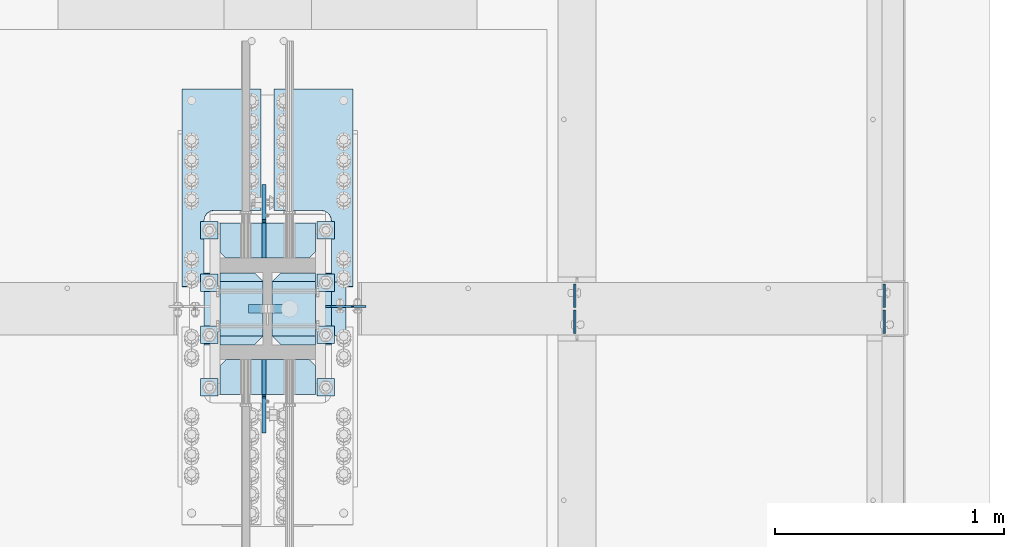
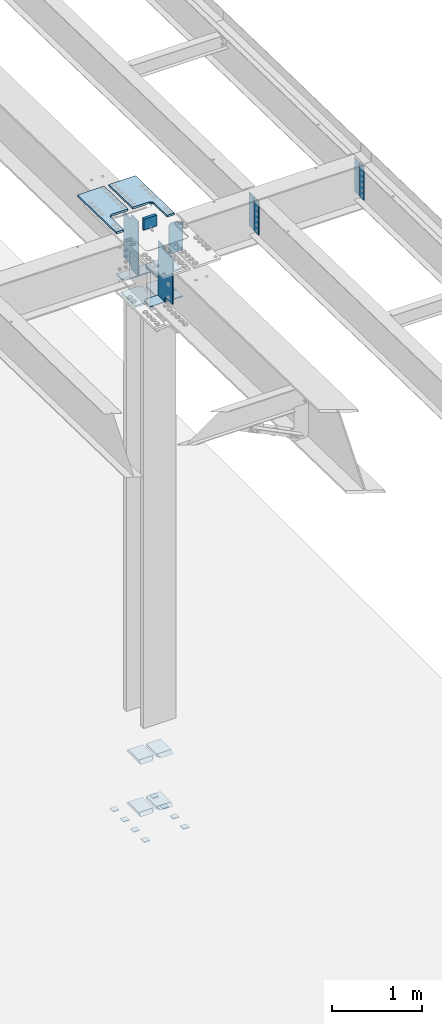
# One storey, part 1572 of 1763: 27 plates, 5 elements without a shape of their own.
"""IFC2X3 building model written with IfcOpenShell, lengths in millimetres."""

from ifc_helpers import new_model, si_unit, frame, origin_with_axes, place, context, subcontext, project, spatial, faceted_brep, material, type_object, element, aggregate, save


model = new_model("IFC2X3")

# Units and contexts
model_context = context("Model", 3, precision=1e-05, world=origin_with_axes())
body_context = subcontext(model_context, "Body", "Model", "MODEL_VIEW")
ifc_project = project(units=[si_unit("LENGTHUNIT", "METRE", prefix="MILLI"), si_unit("AREAUNIT", "SQUARE_METRE"), si_unit("VOLUMEUNIT", "CUBIC_METRE"), si_unit("MASSUNIT", "GRAM", prefix="KILO"), si_unit("TIMEUNIT", "SECOND"), si_unit("PLANEANGLEUNIT", "RADIAN"), si_unit("SOLIDANGLEUNIT", "STERADIAN"), si_unit("THERMODYNAMICTEMPERATUREUNIT", "DEGREE_CELSIUS"), si_unit("LUMINOUSINTENSITYUNIT", "LUMEN")], contexts=[model_context])

# Site, building, storey
site_placement = place(None, origin_with_axes())
site = spatial("IfcSite", under=ifc_project, at=site_placement, CompositionType="ELEMENT")
building_placement = place(site_placement, origin_with_axes())
building = spatial("IfcBuilding", under=site, at=building_placement, Name="Undefined", CompositionType="ELEMENT")
storey_placement = place(building_placement, origin_with_axes())
storey = spatial("IfcBuildingStorey", under=building, at=storey_placement, Name="Undefined", CompositionType="ELEMENT", Elevation=0.0)

# Assembly, plates
assembly_1_placement = place(storey_placement, origin_with_axes())
assembly_1 = element("IfcElementAssembly", 1, at=assembly_1_placement, inside=storey, Name="TEMPLATE", AssemblyPlace="NOTDEFINED", PredefinedType="RIGID_FRAME")
ifc_material_1 = material(Name="STEEL/A36")
plate_type_1 = type_object("IfcPlateType", PredefinedType="NOTDEFINED")
plate_1_placement = place(assembly_1_placement, frame((-24243.7372736984, 152.399999999998, 3916.3625), z_axis=(-1.0, 0.0, 0.0), x_axis=(0.0, -1.0, 0.0)))
plate_1 = element("IfcPlate", 2, at=plate_1_placement, type_object=plate_type_1, material=ifc_material_1, Name="WASHER PLATE", context=body_context, shape_type="Brep", body=[
    faceted_brep([(0.0, -4.76249999999982, 0.0), (0.0, -4.76250000000073, 76.1999969482422), (0.0, 4.76250000000073, 76.1999969482422), (0.0, 4.76249999999982, 0.0), (76.1999969482422, -4.76249999999982, 76.1999969482422), (76.1999969482422, 4.76249999999982, 76.1999969482422), (76.1999969482931, -4.76249999991705, 0.0), (76.1999969482931, 4.76250000006257, 1.81898940354586e-12)], [[[0, 1, 2, 3]], [[1, 4, 5, 2]], [[4, 6, 7, 5]], [[6, 0, 3, 7]], [[5, 7, 3, 2]], [[6, 4, 1, 0]]]),
])
plate_2_placement = place(assembly_1_placement, frame((-23735.7372736984, 152.399999999998, 3916.3625), z_axis=(-1.0, 0.0, 0.0), x_axis=(0.0, -1.0, 0.0)))
plate_2 = element("IfcPlate", 3, at=plate_2_placement, type_object=plate_type_1, material=ifc_material_1, Name="WASHER PLATE", context=body_context, shape_type="Brep", body=[
    faceted_brep([(0.0, -4.76249999999982, 0.0), (0.0, -4.76250000000073, 76.1999969482422), (0.0, 4.76250000000073, 76.1999969482422), (0.0, 4.76249999999982, 0.0), (76.1999969482422, -4.76249999999982, 76.1999969482422), (76.1999969482422, 4.76249999999982, 76.1999969482422), (76.1999969482931, -4.76249999991705, 0.0), (76.1999969482931, 4.76250000006257, 1.81898940354586e-12)], [[[0, 1, 2, 3]], [[1, 4, 5, 2]], [[4, 6, 7, 5]], [[6, 0, 3, 7]], [[5, 7, 3, 2]], [[6, 4, 1, 0]]]),
])
plate_3_placement = place(assembly_1_placement, frame((-24243.7372736984, 380.999999999998, 3916.3625), z_axis=(-1.0, 0.0, 0.0), x_axis=(0.0, -1.0, 0.0)))
plate_3 = element("IfcPlate", 4, at=plate_3_placement, type_object=plate_type_1, material=ifc_material_1, Name="WASHER PLATE", context=body_context, shape_type="Brep", body=[
    faceted_brep([(0.0, -4.76249999999982, 0.0), (0.0, -4.76250000000073, 76.1999969482422), (0.0, 4.76250000000073, 76.1999969482422), (0.0, 4.76249999999982, 0.0), (76.1999969482422, -4.76249999999982, 76.1999969482422), (76.1999969482422, 4.76249999999982, 76.1999969482422), (76.1999969482931, -4.76249999991705, 0.0), (76.1999969482931, 4.76250000006257, 1.81898940354586e-12)], [[[0, 1, 2, 3]], [[1, 4, 5, 2]], [[4, 6, 7, 5]], [[6, 0, 3, 7]], [[5, 7, 3, 2]], [[6, 4, 1, 0]]]),
])
plate_4_placement = place(assembly_1_placement, frame((-23735.7372736984, 380.999999999998, 3916.3625), z_axis=(-1.0, 0.0, 0.0), x_axis=(0.0, -1.0, 0.0)))
plate_4 = element("IfcPlate", 5, at=plate_4_placement, type_object=plate_type_1, material=ifc_material_1, Name="WASHER PLATE", context=body_context, shape_type="Brep", body=[
    faceted_brep([(0.0, -4.76249999999982, 0.0), (0.0, -4.76250000000073, 76.1999969482422), (0.0, 4.76250000000073, 76.1999969482422), (0.0, 4.76249999999982, 0.0), (76.1999969482422, -4.76249999999982, 76.1999969482422), (76.1999969482422, 4.76249999999982, 76.1999969482422), (76.1999969482931, -4.76249999991705, 0.0), (76.1999969482931, 4.76250000006257, 1.81898940354586e-12)], [[[0, 1, 2, 3]], [[1, 4, 5, 2]], [[4, 6, 7, 5]], [[6, 0, 3, 7]], [[5, 7, 3, 2]], [[6, 4, 1, 0]]]),
])
plate_5_placement = place(assembly_1_placement, frame((-24243.7372736984, 609.599999999998, 3916.3625), z_axis=(-1.0, 0.0, 0.0), x_axis=(0.0, -1.0, 0.0)))
plate_5 = element("IfcPlate", 6, at=plate_5_placement, type_object=plate_type_1, material=ifc_material_1, Name="WASHER PLATE", context=body_context, shape_type="Brep", body=[
    faceted_brep([(0.0, -4.76249999999982, 0.0), (0.0, -4.76250000000073, 76.1999969482422), (0.0, 4.76250000000073, 76.1999969482422), (0.0, 4.76249999999982, 0.0), (76.1999969482422, -4.76249999999982, 76.1999969482422), (76.1999969482422, 4.76249999999982, 76.1999969482422), (76.1999969482931, -4.76249999991705, 0.0), (76.1999969482931, 4.76250000006257, 1.81898940354586e-12)], [[[0, 1, 2, 3]], [[1, 4, 5, 2]], [[4, 6, 7, 5]], [[6, 0, 3, 7]], [[5, 7, 3, 2]], [[6, 4, 1, 0]]]),
])
plate_6_placement = place(assembly_1_placement, frame((-23735.7372736984, 609.599999999998, 3916.3625), z_axis=(-1.0, 0.0, 0.0), x_axis=(0.0, -1.0, 0.0)))
plate_6 = element("IfcPlate", 7, at=plate_6_placement, type_object=plate_type_1, material=ifc_material_1, Name="WASHER PLATE", context=body_context, shape_type="Brep", body=[
    faceted_brep([(0.0, -4.76249999999982, 0.0), (0.0, -4.76250000000073, 76.1999969482422), (0.0, 4.76250000000073, 76.1999969482422), (0.0, 4.76249999999982, 0.0), (76.1999969482422, -4.76249999999982, 76.1999969482422), (76.1999969482422, 4.76249999999982, 76.1999969482422), (76.1999969482931, -4.76249999991705, 0.0), (76.1999969482931, 4.76250000006257, 1.81898940354586e-12)], [[[0, 1, 2, 3]], [[1, 4, 5, 2]], [[4, 6, 7, 5]], [[6, 0, 3, 7]], [[5, 7, 3, 2]], [[6, 4, 1, 0]]]),
])
plate_7_placement = place(assembly_1_placement, frame((-24243.7372736984, 838.199999999998, 3916.3625), z_axis=(-1.0, 0.0, 0.0), x_axis=(0.0, -1.0, 0.0)))
plate_7 = element("IfcPlate", 8, at=plate_7_placement, type_object=plate_type_1, material=ifc_material_1, Name="WASHER PLATE", context=body_context, shape_type="Brep", body=[
    faceted_brep([(0.0, -4.76249999999982, 0.0), (0.0, -4.76250000000073, 76.1999969482422), (0.0, 4.76250000000073, 76.1999969482422), (0.0, 4.76249999999982, 0.0), (76.1999969482422, -4.76249999999982, 76.1999969482422), (76.1999969482422, 4.76249999999982, 76.1999969482422), (76.1999969482931, -4.76249999991705, 0.0), (76.1999969482931, 4.76250000006257, 1.81898940354586e-12)], [[[0, 1, 2, 3]], [[1, 4, 5, 2]], [[4, 6, 7, 5]], [[6, 0, 3, 7]], [[5, 7, 3, 2]], [[6, 4, 1, 0]]]),
])
plate_8_placement = place(assembly_1_placement, frame((-23735.7372736984, 838.199999999998, 3916.3625), z_axis=(-1.0, 0.0, 0.0), x_axis=(0.0, -1.0, 0.0)))
plate_8 = element("IfcPlate", 9, at=plate_8_placement, type_object=plate_type_1, material=ifc_material_1, Name="WASHER PLATE", context=body_context, shape_type="Brep", body=[
    faceted_brep([(0.0, -4.76249999999982, 0.0), (0.0, -4.76250000000073, 76.1999969482422), (0.0, 4.76250000000073, 76.1999969482422), (0.0, 4.76249999999982, 0.0), (76.1999969482422, -4.76249999999982, 76.1999969482422), (76.1999969482422, 4.76249999999982, 76.1999969482422), (76.1999969482931, -4.76249999991705, 0.0), (76.1999969482931, 4.76250000006257, 1.81898940354586e-12)], [[[0, 1, 2, 3]], [[1, 4, 5, 2]], [[4, 6, 7, 5]], [[6, 0, 3, 7]], [[5, 7, 3, 2]], [[6, 4, 1, 0]]]),
])
aggregate(assembly_1, [plate_1, plate_2, plate_3, plate_4, plate_5, plate_6, plate_7, plate_8])

assembly_2_placement = place(storey_placement, origin_with_axes())
assembly_2 = element("IfcElementAssembly", 10, at=assembly_2_placement, inside=storey, Name="COLUMN", AssemblyPlace="NOTDEFINED", PredefinedType="RIGID_FRAME")
plate_type_2 = type_object("IfcPlateType", PredefinedType="NOTDEFINED")
plate_9_placement = place(assembly_2_placement, frame((-24235.7997736984, 300.037499999998, 4114.80000000001), z_axis=(0.0, 1.0, 0.0), x_axis=(1.0, 0.0, 0.0)))
plate_9 = element("IfcPlate", 11, at=plate_9_placement, type_object=plate_type_2, material=ifc_material_1, Name="PLATE", context=body_context, shape_type="Brep", body=[
    faceted_brep([(188.118743896484, -19.0500000000002, 276.22501373291), (150.018745422363, 19.0500000000002, 314.325012207031), (0.0, 19.0500000000002, 314.325012207031), (0.0, -19.0500000000002, 276.225012209207), (188.118743896484, -19.0500000000002, 38.0999984741211), (0.0, -19.0500000000002, 38.099999997823), (0.0, 19.0500000000029, 0.0), (150.018745422363, 19.0500000000002, 0.0), (188.118743896484, 19.0500000000002, 38.0999984741211), (188.118743896484, 19.0500000000002, 276.22501373291)], [[[0, 1, 2, 3]], [[4, 5, 6, 7]], [[8, 4, 7]], [[0, 4, 8, 9]], [[5, 4, 0, 3]], [[6, 5, 3, 2]], [[9, 8, 7, 6, 2, 1]], [[9, 1, 0]]]),
])
plate_10_placement = place(assembly_2_placement, frame((-24007.9935236984, 300.037499999998, 4114.80000000001), z_axis=(0.0, 1.0, 0.0), x_axis=(1.0, 0.0, 0.0)))
plate_10 = element("IfcPlate", 12, at=plate_10_placement, type_object=plate_type_2, material=ifc_material_1, Name="PLATE", context=body_context, shape_type="Brep", body=[
    faceted_brep([(188.118743896484, -19.0500000000002, 38.0999984741211), (0.0, -19.0500000000002, 38.099999997823), (38.0999984741211, 19.0500000000002, 0.0), (188.118743896484, 19.0500000000002, 0.0), (0.0, 19.0500000000002, 38.0999984741211), (0.0, 19.0500000000002, 276.22501373291), (0.0, -19.0500000000002, 276.225012209207), (38.0999984741211, 19.0500000000002, 314.325012207031), (188.118743896484, 19.0500000000002, 314.325012207031), (188.118743896484, -19.0500000000002, 276.22501373291)], [[[0, 1, 2, 3]], [[4, 2, 1]], [[5, 6, 7]], [[8, 7, 6, 9]], [[8, 9, 0, 3]], [[4, 5, 7, 8, 3, 2]], [[1, 6, 5, 4]], [[1, 0, 9, 6]]]),
])
plate_11_placement = place(assembly_2_placement, frame((-24235.7997736984, 300.037499999998, 4826.00000000001), z_axis=(0.0, 1.0, 0.0), x_axis=(1.0, 0.0, 0.0)))
plate_11 = element("IfcPlate", 13, at=plate_11_placement, type_object=plate_type_2, material=ifc_material_1, Name="PLATE", context=body_context, shape_type="Brep", body=[
    faceted_brep([(188.118743896484, -19.0500000000002, 276.22501373291), (150.018745422363, 19.0500000000002, 314.325012207031), (0.0, 19.0500000000002, 314.325012207031), (0.0, -19.0500000000002, 276.225012209207), (188.118743896484, -19.0500000000002, 38.0999984741211), (0.0, -19.0500000000002, 38.099999997823), (0.0, 19.0500000000029, 0.0), (150.018745422363, 19.0500000000002, 0.0), (188.118743896484, 19.0500000000002, 38.0999984741211), (188.118743896484, 19.0500000000002, 276.22501373291)], [[[0, 1, 2, 3]], [[4, 5, 6, 7]], [[8, 4, 7]], [[0, 4, 8, 9]], [[5, 4, 0, 3]], [[6, 5, 3, 2]], [[9, 8, 7, 6, 2, 1]], [[9, 1, 0]]]),
])
plate_12_placement = place(assembly_2_placement, frame((-24007.9935236984, 300.037499999998, 4826.00000000001), z_axis=(0.0, 1.0, 0.0), x_axis=(1.0, 0.0, 0.0)))
plate_12 = element("IfcPlate", 14, at=plate_12_placement, type_object=plate_type_2, material=ifc_material_1, Name="PLATE", context=body_context, shape_type="Brep", body=[
    faceted_brep([(188.118743896484, -19.0500000000002, 38.0999984741211), (0.0, -19.0500000000002, 38.099999997823), (38.0999984741211, 19.0500000000002, 0.0), (188.118743896484, 19.0500000000002, 0.0), (0.0, 19.0500000000002, 38.0999984741211), (0.0, 19.0500000000002, 276.22501373291), (0.0, -19.0500000000002, 276.225012209207), (38.0999984741211, 19.0500000000002, 314.325012207031), (188.118743896484, 19.0500000000002, 314.325012207031), (188.118743896484, -19.0500000000002, 276.22501373291)], [[[0, 1, 2, 3]], [[4, 2, 1]], [[5, 6, 7]], [[8, 7, 6, 9]], [[8, 9, 0, 3]], [[4, 5, 7, 8, 3, 2]], [[1, 6, 5, 4]], [[1, 0, 9, 6]]]),
])

assembly_3_placement = place(storey_placement, origin_with_axes())
assembly_3 = element("IfcElementAssembly", 15, at=assembly_3_placement, inside=storey, Name="BEAM", AssemblyPlace="NOTDEFINED", PredefinedType="RIGID_FRAME")
plate_type_3 = type_object("IfcPlateType", PredefinedType="NOTDEFINED")
plate_13_placement = place(assembly_3_placement, frame((-22687.1937736983, 462.756250000002, 11868.8358367707), z_axis=(0.0, 1.0, 0.0), x_axis=(0.0, 0.0, -1.0)))
plate_13 = element("IfcPlate", 16, at=plate_13_placement, type_object=plate_type_3, material=ifc_material_1, Name="PLATE", context=body_context, shape_type="Brep", body=[
    faceted_brep([(0.0, -3.96900000000096, 0.0), (-1.18234311230481e-11, -3.96900000000096, 101.599998474121), (-1.18234311230481e-11, 3.96900000000096, 101.599998474121), (0.0, 3.96900000000096, 0.0), (457.200012207031, -3.96900000000096, 101.599998474121), (457.200012207031, 3.96900000000096, 101.599998474121), (457.200012207031, -3.96900000000096, 0.0), (457.200012207031, 3.96900000000096, 0.0)], [[[0, 1, 2, 3]], [[1, 4, 5, 2]], [[4, 6, 7, 5]], [[6, 0, 3, 7]], [[5, 7, 3, 2]], [[6, 4, 1, 0]]]),
])
plate_14_placement = place(assembly_3_placement, frame((-21337.8187736983, 462.756250000002, 11868.8358367707), z_axis=(0.0, 1.0, 0.0), x_axis=(0.0, 0.0, -1.0)))
plate_14 = element("IfcPlate", 17, at=plate_14_placement, type_object=plate_type_3, material=ifc_material_1, Name="PLATE", context=body_context, shape_type="Brep", body=[
    faceted_brep([(0.0, -3.96900000000096, 0.0), (-1.18234311230481e-11, -3.96900000000096, 101.599998474121), (-1.18234311230481e-11, 3.96900000000096, 101.599998474121), (0.0, 3.96900000000096, 0.0), (457.200012207031, -3.96900000000096, 101.599998474121), (457.200012207031, 3.96900000000096, 101.599998474121), (457.200012207031, -3.96900000000096, 0.0), (457.200012207031, 3.96900000000096, 0.0)], [[[0, 1, 2, 3]], [[1, 4, 5, 2]], [[4, 6, 7, 5]], [[6, 0, 3, 7]], [[5, 7, 3, 2]], [[6, 4, 1, 0]]]),
])
plate_15_placement = place(assembly_3_placement, frame((-21337.8187736984, 451.643750000003, 11871.723207307), z_axis=(0.0, -1.0, 0.0), x_axis=(0.0, 0.0, -1.0)))
plate_15 = element("IfcPlate", 18, at=plate_15_placement, type_object=plate_type_3, material=ifc_material_1, Name="PLATE", context=body_context, shape_type="Brep", body=[
    faceted_brep([(0.0, -3.96900000000096, 0.0), (-1.18234311230481e-11, -3.96900000000096, 101.599998474121), (-1.18234311230481e-11, 3.96900000000096, 101.599998474121), (0.0, 3.96900000000096, 0.0), (457.200012207031, -3.96900000000096, 101.599998474121), (457.200012207031, 3.96900000000096, 101.599998474121), (457.200012207031, -3.96900000000096, 0.0), (457.200012207031, 3.96900000000096, 0.0)], [[[0, 1, 2, 3]], [[1, 4, 5, 2]], [[4, 6, 7, 5]], [[6, 0, 3, 7]], [[5, 7, 3, 2]], [[6, 4, 1, 0]]]),
])
plate_16_placement = place(assembly_3_placement, frame((-22687.1937736984, 451.643750000003, 11871.723207307), z_axis=(0.0, -1.0, 0.0), x_axis=(0.0, 0.0, -1.0)))
plate_16 = element("IfcPlate", 19, at=plate_16_placement, type_object=plate_type_3, material=ifc_material_1, Name="PLATE", context=body_context, shape_type="Brep", body=[
    faceted_brep([(0.0, -3.96900000000096, 0.0), (-1.18234311230481e-11, -3.96900000000096, 101.599998474121), (-1.18234311230481e-11, 3.96900000000096, 101.599998474121), (0.0, 3.96900000000096, 0.0), (457.200012207031, -3.96900000000096, 101.599998474121), (457.200012207031, 3.96900000000096, 101.599998474121), (457.200012207031, -3.96900000000096, 0.0), (457.200012207031, 3.96900000000096, 0.0)], [[[0, 1, 2, 3]], [[1, 4, 5, 2]], [[4, 6, 7, 5]], [[6, 0, 3, 7]], [[5, 7, 3, 2]], [[6, 4, 1, 0]]]),
])
aggregate(assembly_3, [plate_13, plate_14, plate_15, plate_16])

# Plate
ifc_material_2 = material(Name="STEEL/A572-50")
plate_type_4 = type_object("IfcPlateType", PredefinedType="NOTDEFINED")
plate_17_placement = place(assembly_2_placement, frame((-23819.8747736984, 82.5499450683583, 11144.523238352), z_axis=(-1.0, 0.0, 0.0), x_axis=(0.0, 1.0, 0.0)))
plate_17 = element("IfcPlate", 20, at=plate_17_placement, type_object=plate_type_4, material=ifc_material_2, Name="PLATE", context=body_context, shape_type="Brep", body=[
    faceted_brep([(0.0, -6.34999999999491, 1.45519152283669e-11), (0.0, -6.35000000000036, 415.924987792969), (0.0, 6.35000000000036, 415.924987792969), (0.0, 6.34999999999491, -2.91038304567337e-11), (127.00005531311, -6.35000000000036, 415.924987792969), (127.00005531311, 6.35000000000036, 415.924987792969), (152.400054931641, -6.35000000000036, 390.524988174438), (152.400054931641, 6.35000000000036, 390.524988174438), (152.400054931641, -6.35000000000036, 25.3999996185375), (152.400054931641, 6.35000000000036, 25.3999996185375), (127.00005531311, -6.35000000000036, 7.27595761418343e-12), (127.00005531311, 6.35000000000036, 7.27595761418343e-12)], [[[0, 1, 2, 3]], [[1, 4, 5, 2]], [[4, 6, 7, 5]], [[6, 8, 9, 7]], [[8, 10, 11, 9]], [[10, 0, 3, 11]], [[5, 7, 9, 11, 3, 2]], [[10, 8, 6, 4, 1, 0]]]),
])

plate_18_placement = place(assembly_2_placement, frame((-23819.8747736984, 679.449999999999, 11135.2305555584), z_axis=(-1.0, 0.0, 0.0), x_axis=(0.0, 1.0, 0.0)))
plate_18 = element("IfcPlate", 21, at=plate_18_placement, type_object=plate_type_4, material=ifc_material_2, Name="PLATE", context=body_context, shape_type="Brep", body=[
    faceted_brep([(0.0, -6.35000000000036, 25.3999996185303), (0.0, -6.35000000000036, 390.524988174438), (0.0, 6.35000000000036, 390.524988174438), (-2.63229335373174e-12, 6.34999999999999, 25.3999996185303), (25.3999996185303, -6.35000000000036, 415.924987792969), (25.3999996185303, 6.35000000000036, 415.924987792969), (152.400054931641, -6.35000000000036, 415.924987792969), (152.400054931641, 6.35000000000036, 415.924987792969), (152.400054931641, -6.35000000000036, 7.27595761418343e-12), (152.400054931641, 6.35000000000036, 7.27595761418343e-12), (25.3999996185339, -6.35000000000582, 0.0), (25.3999996185339, 6.35000000000582, 0.0)], [[[0, 1, 2, 3]], [[1, 4, 5, 2]], [[4, 6, 7, 5]], [[6, 8, 9, 7]], [[8, 10, 11, 9]], [[10, 0, 3, 11]], [[5, 7, 9, 11, 3, 2]], [[10, 8, 6, 4, 1, 0]]]),
])

plate_type_5 = type_object("IfcPlateType", PredefinedType="NOTDEFINED")
plate_19_placement = place(assembly_2_placement, frame((-24305.6497736984, 300.037499999998, 11039.9805555584), z_axis=(0.0, 1.0, 0.0), x_axis=(1.0, 0.0, 0.0)))
plate_19 = element("IfcPlate", 22, at=plate_19_placement, type_object=plate_type_5, material=ifc_material_2, Name="PLATE", context=body_context, shape_type="Brep", body=[
    faceted_brep([(0.0, -12.6999999999971, -1.81898940354586e-12), (0.0, -12.7000000000007, 314.325012207031), (0.0, 12.7000000000007, 314.325012207031), (0.0, 12.6999999999971, -1.81898940354586e-12), (219.868751525879, -12.7000000000007, 314.325012207031), (219.868751525879, 12.7000000000007, 314.325012207031), (257.96875, -12.7000000000007, 276.22501373291), (257.96875, 12.7000000000007, 276.22501373291), (257.96875, -12.7000000000007, 38.0999984741211), (257.96875, 12.7000000000007, 38.0999984741211), (219.868751525879, -12.7000000000007, 0.0), (219.868751525879, 12.7000000000007, 0.0)], [[[0, 1, 2, 3]], [[1, 4, 5, 2]], [[4, 6, 7, 5]], [[6, 8, 9, 7]], [[8, 10, 11, 9]], [[10, 0, 3, 11]], [[5, 7, 9, 11, 3, 2]], [[10, 8, 6, 4, 1, 0]]]),
])

plate_20_placement = place(assembly_2_placement, frame((-24007.9935236984, 300.037499999998, 11039.9805555584), z_axis=(0.0, 1.0, 0.0), x_axis=(1.0, 0.0, 0.0)))
plate_20 = element("IfcPlate", 23, at=plate_20_placement, type_object=plate_type_5, material=ifc_material_2, Name="PLATE", context=body_context, shape_type="Brep", body=[
    faceted_brep([(0.0, -12.7000000000007, 38.0999984741211), (0.0, -12.7000000000007, 276.22501373291), (0.0, 12.7000000000007, 276.22501373291), (0.0, 12.7000000000007, 38.0999984741211), (38.0999984741211, -12.7000000000007, 314.325012207031), (38.0999984741211, 12.7000000000007, 314.325012207031), (257.96875, -12.7000000000007, 314.325012207031), (257.96875, 12.7000000000007, 314.325012207031), (257.96875, -12.7000000000007, 0.0), (257.96875, 12.7000000000007, 0.0), (38.0999984741211, -12.7000000000007, 0.0), (38.0999984741211, 12.7000000000007, 0.0)], [[[0, 1, 2, 3]], [[1, 4, 5, 2]], [[4, 6, 7, 5]], [[6, 8, 9, 7]], [[8, 10, 11, 9]], [[10, 0, 3, 11]], [[5, 7, 9, 11, 3, 2]], [[10, 8, 6, 4, 1, 0]]]),
])

plate_type_6 = type_object("IfcPlateType", PredefinedType="NOTDEFINED")
plate_21_placement = place(assembly_2_placement, frame((-24007.9935236984, 300.037499999998, 11313.0836714953), z_axis=(0.0, 1.0, 0.0), x_axis=(1.0, 0.0, 0.0)))
plate_21 = element("IfcPlate", 24, at=plate_21_placement, type_object=plate_type_6, material=ifc_material_2, Name="PLATE", context=body_context, shape_type="Brep", body=[
    faceted_brep([(11.1125007607625, -11.1124999999993, 287.337514493672), (0.0, 7.60761395213194e-07, 276.22501373291), (0.0, 0.0, 38.0999984741211), (11.1125007607625, -11.1124999999993, 26.9874977133604), (321.468750000004, -11.1124999999993, 273.050000269884), (321.46875, 11.1124999999993, 273.050000269884), (186.531250000004, 11.1124999999993, 273.050000000016), (186.531250000004, -11.1124999999993, 273.050000000016), (321.468749917418, -11.1124999999993, 41.2750091555299), (321.46875, 11.1124999999993, 41.2750091555299), (38.0999984741211, -11.1124999999993, 0.0), (38.0999984741211, 11.1124999999993, 0.0), (186.53125, 11.1124999999993, 0.0), (186.53125, -11.1124999999993, 0.0), (186.531250004886, 11.1124999999993, 41.2750088856577), (186.531250004886, -11.1124999999993, 41.2750088856577), (0.0, 11.1124999999993, 38.0999984741211), (0.0, 11.1124999999993, 276.22501373291), (38.0999984741211, 11.1124999999993, 314.325012207031), (186.531250004886, 11.1124999999993, 314.325012207031), (186.531250004886, -11.1124999999993, 314.325012207031), (38.0999984741211, -11.1124999999993, 314.325012207031)], [[[0, 1, 2, 3]], [[4, 5, 6, 7]], [[5, 4, 8, 9]], [[10, 11, 12, 13]], [[13, 12, 14, 15]], [[8, 15, 14, 9]], [[12, 11, 16, 17, 18, 19, 6, 5, 9, 14]], [[20, 7, 6, 19]], [[18, 21, 20, 19]], [[10, 13, 15, 8, 4, 7, 20, 21, 0, 3]], [[16, 11, 10, 3, 2]], [[17, 16, 2, 1]], [[21, 18, 17, 1, 0]]]),
])

plate_type_7 = type_object("IfcPlateType", PredefinedType="NOTDEFINED")
plate_22_placement = place(assembly_2_placement, frame((-24043.7122736984, 679.450000000496, 11874.8080929798), z_axis=(0.0, 1.0, 0.0), x_axis=(0.0, 0.0, -1.0)))
plate_22 = element("IfcPlate", 25, at=plate_22_placement, type_object=plate_type_7, material=ifc_material_2, Name="PLATE", context=body_context, shape_type="Brep", body=[
    faceted_brep([(36.5138878878406, -7.9375, 152.400054931638), (36.5138878878406, 7.9375, 152.400054931638), (-6.91215973347425e-11, 7.9375, 152.400054931638), (-6.91215973347425e-11, -7.9375, 152.400054931638), (46.2340469239316, -7.9375, 154.333514776814), (46.2340469239316, 7.9375, 154.333514776814), (54.4743998602389, -7.9375, 159.83954257777), (54.4743998602389, 7.9375, 159.83954257777), (59.9804276611958, -7.9375, 168.079895514078), (59.9804276611958, 7.9375, 168.079895514078), (61.9138875063709, -7.9375, 177.800054550169), (61.9138875063709, 7.9375, 177.800054550169), (61.9138875063709, -7.9375, 320.674987792966), (61.9138875063709, 7.9375, 320.674987792969), (731.837524414062, -7.9375, -3.3276137401117e-10), (-7.27595761418343e-12, -7.9375, 0.0), (-7.27595761418343e-12, 7.9375, 0.0), (731.837524414062, 7.9375, -3.3276137401117e-10), (731.837524414062, 7.9375, 152.400054931638), (731.837524414062, -7.9375, 152.400054931638), (703.263915287378, 7.9375, 152.400054931638), (703.263915287378, -7.9375, 152.400054931638), (693.543756251287, 7.9375, 154.333514776814), (693.543756251287, -7.9375, 154.333514776814), (685.30340331498, 7.9375, 159.83954257777), (685.30340331498, -7.9375, 159.83954257777), (679.797375514023, 7.9375, 168.079895514078), (679.797375514023, -7.9375, 168.079895514078), (677.863915668848, 7.9375, 177.800054550169), (677.863915668848, -7.9375, 177.800054550169), (677.863915668848, -7.9375, 320.674987792969), (677.863915668848, 7.9375, 320.674987792969)], [[[0, 1, 2, 3]], [[4, 5, 1, 0]], [[6, 7, 5, 4]], [[8, 9, 7, 6]], [[10, 11, 9, 8]], [[12, 13, 11, 10]], [[14, 15, 16, 17]], [[14, 17, 18, 19]], [[19, 18, 20, 21]], [[21, 20, 22, 23]], [[23, 22, 24, 25]], [[25, 24, 26, 27]], [[27, 26, 28, 29]], [[30, 29, 28, 31]], [[8, 6, 4, 0, 3, 15, 14, 19, 21, 23, 25, 27, 29, 30, 12, 10]], [[16, 15, 3, 2]], [[31, 28, 26, 24, 22, 20, 18, 17, 16, 2, 1, 5, 7, 9, 11, 13]], [[30, 31, 13, 12]]]),
])

plate_23_placement = place(assembly_2_placement, frame((-24043.7122736984, 234.950000000491, 11886.2524754753), z_axis=(0.0, -1.0, 0.0), x_axis=(0.0, 0.0, -1.0)))
plate_23 = element("IfcPlate", 26, at=plate_23_placement, type_object=plate_type_7, material=ifc_material_2, Name="PLATE", context=body_context, shape_type="Brep", body=[
    faceted_brep([(22.2250003816389, -7.9375, 152.399993896479), (22.2250003816389, 7.9375, 152.399993896479), (7.27595761418343e-12, 7.9375, 152.399993896484), (7.27595761418343e-12, -7.9375, 152.399993896484), (31.9451594177299, -7.9375, 154.333453741654), (31.9451594177299, 7.9375, 154.333453741654), (40.1855123540372, -7.9375, 159.83948154261), (40.1855123540372, 7.9375, 159.83948154261), (45.6915401549941, -7.9375, 168.079834478918), (45.6915401549941, 7.9375, 168.079834478918), (47.6250000001692, -7.9375, 177.799993515009), (47.6250000001692, 7.9375, 177.799993515009), (47.6250000001692, -7.9375, 320.674987792963), (47.6250000001692, 7.9375, 320.674987792969), (735.012512207031, -7.9375, 3.34239302901551e-10), (-7.27595761418343e-12, -7.9375, 0.0), (-7.27595761418343e-12, 7.9375, 0.0), (735.012512207031, 7.9375, 3.34239302901551e-10), (735.012512207031, 7.9375, 152.400000000501), (735.012512207031, -7.9375, 152.400000000501), (696.829604374292, 7.9375, 152.400000000501), (696.829604374292, -7.9375, 152.400000000501), (687.109445338201, 7.9375, 154.333459845677), (687.109445338201, -7.9375, 154.333459845677), (678.869092401894, 7.9375, 159.839487646633), (678.869092401894, -7.9375, 159.839487646633), (673.363064600937, 7.9375, 168.07984058294), (673.363064600937, -7.9375, 168.07984058294), (671.429604755762, 7.9375, 177.799999619032), (671.429604755762, -7.9375, 177.799999619032), (671.429604755762, -7.9375, 320.674987792969), (671.429604755762, 7.9375, 320.674987792969)], [[[0, 1, 2, 3]], [[4, 5, 1, 0]], [[6, 7, 5, 4]], [[8, 9, 7, 6]], [[10, 11, 9, 8]], [[12, 13, 11, 10]], [[14, 15, 16, 17]], [[14, 17, 18, 19]], [[19, 18, 20, 21]], [[21, 20, 22, 23]], [[23, 22, 24, 25]], [[25, 24, 26, 27]], [[27, 26, 28, 29]], [[30, 29, 28, 31]], [[8, 6, 4, 0, 3, 15, 14, 19, 21, 23, 25, 27, 29, 30, 12, 10]], [[15, 3, 2, 16]], [[31, 28, 26, 24, 22, 20, 18, 17, 16, 2, 1, 5, 7, 9, 11, 13]], [[30, 31, 13, 12]]]),
])

plate_type_8 = type_object("IfcPlateType", PredefinedType="NOTDEFINED")
plate_24_placement = place(assembly_2_placement, frame((-23945.2872737101, 457.200000000004, 12073.4961623401), z_axis=(0.0, 0.0, -1.0), x_axis=(-1.0, 0.0, 0.0)))
plate_24 = element("IfcPlate", 27, at=plate_24_placement, type_object=plate_type_8, material=ifc_material_2, Name="PLATE", context=body_context, shape_type="Brep", body=[
    faceted_brep([(0.0, 19.05, 146.049990844727), (-1.45519152283669e-11, 7.27595761418343e-12, 165.099990844727), (165.099990844727, 0.0, 165.099990844727), (165.099990844727, 19.05, 146.049990844727), (0.0, -19.05, 146.049990844727), (165.099990844727, -19.05, 146.049990844727), (0.0, 19.0500000000029, 0.0), (0.0, -19.0500000000029, 0.0), (165.10000190921, -19.0500000000029, 0.0), (165.10000190921, 19.0500000000029, 0.0)], [[[0, 1, 2, 3]], [[1, 4, 5, 2]], [[6, 7, 4, 1, 0]], [[5, 8, 9, 3, 2]], [[8, 7, 6, 9]], [[9, 6, 0, 3]], [[7, 8, 5, 4]]]),
])

ifc_material_3 = material(Name="STEEL/A572-GR.50")
plate_type_9 = type_object("IfcPlateType", PredefinedType="NOTDEFINED")
plate_25_placement = place(assembly_2_placement, frame((-23775.4247736984, 467.518750000002, 11881.4086714953), z_axis=(1.0, 0.0, 0.0), x_axis=(0.0, 0.0, -1.0)))
plate_25 = element("IfcPlate", 28, at=plate_25_placement, type_object=plate_type_9, material=ifc_material_3, Name="PLATE", context=body_context, shape_type="Brep", body=[
    faceted_brep([(23.8124986648563, -4.76249999999999, 114.300003051765), (23.8124986648563, 4.76249999999999, 114.300003051765), (4.17836417909712e-07, 4.76249999999709, 114.300003051758), (4.17818228015676e-07, -4.76249999999709, 114.300003051758), (28.6725781829027, -4.76249999999999, 115.266732974353), (28.6725781829027, 4.76249999999999, 115.266732974353), (32.7927546510564, -4.76249999999999, 118.01974687483), (32.7927546510564, 4.76249999999999, 118.01974687483), (35.5457685515339, -4.76249999999999, 122.139923342984), (35.5457685515339, 4.76249999999999, 122.139923342984), (36.5124984741215, -4.76249999999999, 127.00000286103), (36.5124984741215, 4.76249999999999, 127.00000286103), (36.5124984741215, -4.76249999999999, 177.800003051765), (36.5124984741215, 4.76249999999999, 177.800003051758), (23.8124996185306, -4.76249999999999, 7.27595761418343e-12), (0.0, -4.76249999999999, 23.8124996185361), (0.0, 4.76249999999999, 23.8124996185361), (23.8124996185306, 4.76249999999999, 0.0), (417.512512207031, 4.76249999999999, 0.0), (417.512512207031, -4.76249999999999, 0.0), (417.512512207031, -4.76249999999999, 177.800003051758), (417.512512207031, 4.76249999999999, 177.800003051758)], [[[0, 1, 2, 3]], [[4, 5, 1, 0]], [[6, 7, 5, 4]], [[8, 9, 7, 6]], [[10, 11, 9, 8]], [[12, 13, 11, 10]], [[14, 15, 16, 17]], [[18, 19, 14, 17]], [[20, 19, 18, 21]], [[8, 6, 4, 0, 3, 15, 14, 19, 20, 12, 10]], [[16, 15, 3, 2]], [[21, 18, 17, 16, 2, 1, 5, 7, 9, 11, 13]], [[20, 21, 13, 12]]]),
])

aggregate(assembly_2, [plate_9, plate_10, plate_11, plate_12, plate_19, plate_21, plate_20, plate_24, plate_17, plate_18, plate_25, plate_22, plate_23])

# Assembly, plate
assembly_4_placement = place(storey_placement, origin_with_axes())
assembly_4 = element("IfcElementAssembly", 29, at=assembly_4_placement, inside=storey, Name="PLATE", AssemblyPlace="NOTDEFINED", PredefinedType="RIGID_FRAME")
plate_type_10 = type_object("IfcPlateType", PredefinedType="NOTDEFINED")
plate_26_placement = place(assembly_4_placement, frame((-24400.8345768876, 553.058951327238, 11919.0949245152), z_axis=(0.0, 0.999781542776098, -0.0209013569953182), x_axis=(1.0, 0.0, 0.0)))
plate_26 = element("IfcPlate", 30, at=plate_26_placement, type_object=plate_type_10, material=ifc_material_2, Name="PLATE", context=body_context, shape_type="Brep", body=[
    faceted_brep([(95.2499921933631, -12.700000000008, 8.5265128291212e-13), (95.2499921933631, 12.700000000008, 2.8421709430404e-13), (95.2499921933595, 12.6999999998152, 288.930016326512), (95.2499921933595, -12.7000000001717, 288.930016529681), (98.6335470313097, 12.6999999998061, 305.940295187102), (98.6335470313097, -12.7000000001844, 305.940295390271), (108.269095993077, 12.6999999997988, 320.36091328973), (108.269095993077, -12.7000000001935, 320.360913492899), (122.689714095704, 12.6999999997915, 329.996462251499), (122.689714095704, -12.700000000199, 329.996462454668), (139.699992956295, 12.6999999997897, 333.380017089448), (139.699992956295, -12.7000000002008, 333.380017292617), (344.487525762695, -12.7000000002008, 333.380017292628), (344.487518310547, 12.6999999997897, 333.380017089459), (0.0, -12.6999999999971, -1.81898940354586e-12), (-3.63797880709171e-12, -12.7000000006265, 863.630004882794), (-3.63797880709171e-12, 12.6999999993604, 863.630004882794), (0.0, 12.6999999999971, -1.81898940354586e-12), (344.487518310547, -12.7000000005301, 863.630004882772), (344.487518310547, 12.6999999994605, 863.630004882773)], [[[0, 1, 2, 3]], [[3, 2, 4, 5]], [[5, 4, 6, 7]], [[7, 6, 8, 9]], [[9, 8, 10, 11]], [[12, 11, 10, 13]], [[14, 15, 16, 17]], [[15, 18, 19, 16]], [[19, 18, 12, 13]], [[8, 6, 4, 2, 1, 17, 16, 19, 13, 10]], [[14, 17, 1, 0]], [[18, 15, 14, 0, 3, 5, 7, 9, 11, 12]]]),
])
aggregate(assembly_4, [plate_26])

assembly_5_placement = place(storey_placement, origin_with_axes())
assembly_5 = element("IfcElementAssembly", 31, at=assembly_5_placement, inside=storey, Name="PLATE", AssemblyPlace="NOTDEFINED", PredefinedType="RIGID_FRAME")
plate_27_placement = place(assembly_5_placement, frame((-23654.7747981124, 553.058951327241, 11919.0949245152), z_axis=(0.0, 0.999781542776098, -0.0209013569953182), x_axis=(-1.0, 0.0, 0.0)))
plate_27 = element("IfcPlate", 32, at=plate_27_placement, type_object=plate_type_10, material=ifc_material_2, Name="PLATE", context=body_context, shape_type="Brep", body=[
    faceted_brep([(95.2499921933631, -12.700000000008, 8.5265128291212e-13), (95.2499921933631, 12.700000000008, 2.8421709430404e-13), (95.2499921933595, 12.6999999998152, 288.930016326512), (95.2499921933595, -12.7000000001717, 288.930016529681), (98.6335470313097, 12.6999999998061, 305.940295187102), (98.6335470313097, -12.7000000001844, 305.940295390271), (108.269095993077, 12.6999999997988, 320.36091328973), (108.269095993077, -12.7000000001935, 320.360913492899), (122.689714095704, 12.6999999997915, 329.996462251499), (122.689714095704, -12.700000000199, 329.996462454668), (139.699992956295, 12.6999999997897, 333.380017089448), (139.699992956295, -12.7000000002008, 333.380017292617), (344.487525762695, -12.7000000002008, 333.380017292628), (344.487518310547, 12.6999999997897, 333.380017089459), (0.0, -12.6999999999971, -1.81898940354586e-12), (-3.63797880709171e-12, -12.7000000006265, 863.630004882794), (-3.63797880709171e-12, 12.6999999993604, 863.630004882794), (0.0, 12.6999999999971, -1.81898940354586e-12), (344.487518310547, -12.7000000005301, 863.630004882772), (344.487518310547, 12.6999999994605, 863.630004882773)], [[[0, 1, 2, 3]], [[3, 2, 4, 5]], [[5, 4, 6, 7]], [[7, 6, 8, 9]], [[9, 8, 10, 11]], [[12, 11, 10, 13]], [[14, 15, 16, 17]], [[15, 18, 19, 16]], [[19, 18, 12, 13]], [[8, 6, 4, 2, 1, 17, 16, 19, 13, 10]], [[14, 17, 1, 0]], [[18, 15, 14, 0, 3, 5, 7, 9, 11, 12]]]),
])
aggregate(assembly_5, [plate_27])

save(model, "model.ifc")
